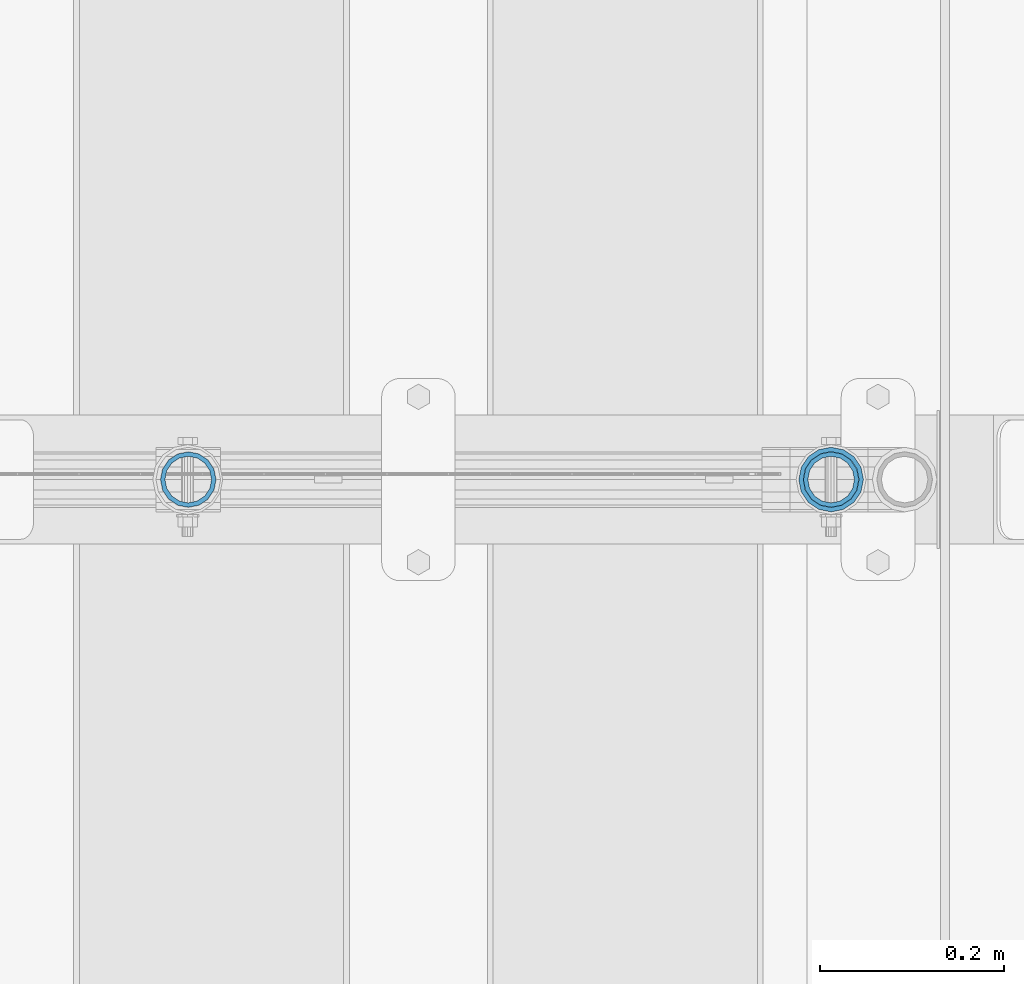
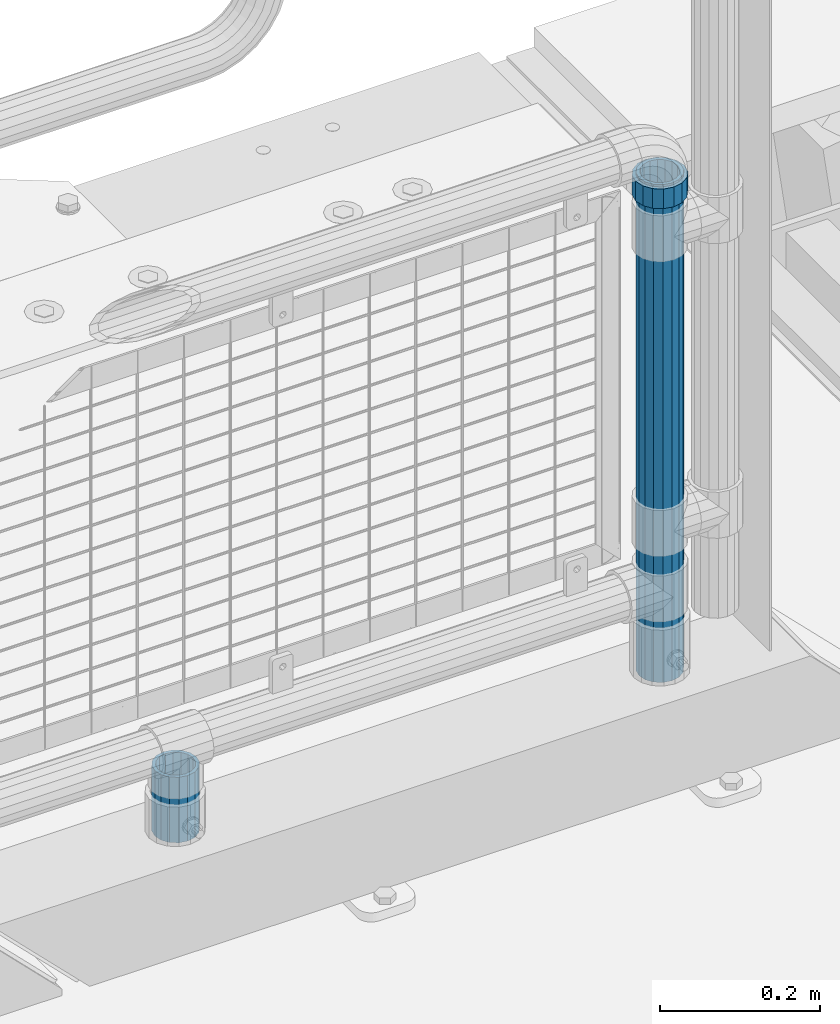
# One storey, part 111 of 270: 3 columns.
"""IFC2X3 building model written with IfcOpenShell, lengths in millimetres."""

from ifc_helpers import new_model, si_unit, frame, origin_with_axes, place, context, subcontext, project, spatial, faceted_brep, material, type_object, element, save


model = new_model("IFC2X3")

# Units and contexts
model_context = context("Model", 3, precision=1e-05, world=origin_with_axes())
body_context = subcontext(model_context, "Body", "Model", "MODEL_VIEW")
ifc_project = project(units=[si_unit("LENGTHUNIT", "METRE", prefix="MILLI"), si_unit("AREAUNIT", "SQUARE_METRE"), si_unit("VOLUMEUNIT", "CUBIC_METRE"), si_unit("MASSUNIT", "GRAM", prefix="KILO"), si_unit("TIMEUNIT", "SECOND"), si_unit("PLANEANGLEUNIT", "RADIAN"), si_unit("SOLIDANGLEUNIT", "STERADIAN"), si_unit("THERMODYNAMICTEMPERATUREUNIT", "DEGREE_CELSIUS"), si_unit("LUMINOUSINTENSITYUNIT", "LUMEN")], contexts=[model_context])

# Site, building, storey
site_placement = place(None, origin_with_axes())
site = spatial("IfcSite", under=ifc_project, at=site_placement, CompositionType="ELEMENT")
building_placement = place(site_placement, origin_with_axes())
building = spatial("IfcBuilding", under=site, at=building_placement, Name="Standard", CompositionType="ELEMENT")
storey_placement = place(building_placement, origin_with_axes())
storey = spatial("IfcBuildingStorey", under=building, at=storey_placement, Name="Undefined", CompositionType="ELEMENT", Elevation=0.0)

# Columns
ifc_material_1 = material()
column_type_1 = type_object("IfcColumnType", PredefinedType="NOTDEFINED")
column_1_placement = place(storey_placement, frame((19794.0, -16335.5, 168.02), z_axis=(-1.0, 0.0, 0.0), x_axis=(0.0, 0.0, 1.0)))
element("IfcColumn", 1, at=column_1_placement, inside=storey, type_object=column_type_1, material=ifc_material_1, context=body_context, shape_type="Brep", body=[
    faceted_brep([(0.0, -25.3500000000004, 0.0), (0.0, -23.4203461491616, 9.70102501045403), (760.0, -23.4203461491616, 9.70102501045403), (760.0, -25.3500000000004, 0.0), (0.0, -17.9251569030785, 17.9251569030785), (760.0, -17.9251569030785, 17.9251569030785), (0.0, -9.70102501045585, 23.4203461491597), (760.0, -9.70102501045585, 23.4203461491597), (0.0, 0.0, 25.3499999999985), (760.0, 0.0, 25.3499999999985), (0.0, 9.70102501045585, 23.4203461491597), (760.0, 9.70102501045585, 23.4203461491597), (0.0, 17.9251569030785, 17.9251569030785), (760.0, 17.9251569030785, 17.9251569030785), (0.0, 23.4203461491616, 9.70102501045403), (760.0, 23.4203461491616, 9.70102501045403), (0.0, 25.3500000000004, 0.0), (760.0, 25.3500000000004, 0.0), (0.0, 23.4203461491616, -9.70102501045403), (760.0, 23.4203461491616, -9.70102501045403), (0.0, 17.9251569030785, -17.9251569030785), (760.0, 17.9251569030785, -17.9251569030785), (0.0, 9.70102501045585, -23.4203461491597), (760.0, 9.70102501045585, -23.4203461491597), (0.0, 0.0, -25.3499999999985), (760.0, 0.0, -25.3499999999985), (0.0, -9.70102501045585, -23.4203461491597), (760.0, -9.70102501045585, -23.4203461491597), (0.0, -17.9251569030785, -17.9251569030785), (760.0, -17.9251569030785, -17.9251569030785), (0.0, -23.4203461491616, -9.70102501045403), (760.0, -23.4203461491616, -9.70102501045403), (0.0, -30.1499999999996, 0.0), (0.0, -27.8549679052157, -11.5379054858058), (760.0, -27.8549679052157, -11.5379054858058), (760.0, -30.1499999999996, 0.0), (0.0, -21.3192694527752, -21.3192694527752), (760.0, -21.3192694527752, -21.3192694527752), (0.0, -11.5379054858076, -27.8549679052157), (760.0, -11.5379054858076, -27.8549679052157), (0.0, 0.0, -30.1500000000015), (760.0, 0.0, -30.1500000000015), (0.0, 11.5379054858076, -27.8549679052157), (760.0, 11.5379054858076, -27.8549679052157), (0.0, 21.3192694527752, -21.3192694527752), (760.0, 21.3192694527752, -21.3192694527752), (0.0, 27.8549679052157, -11.5379054858058), (760.0, 27.8549679052157, -11.5379054858058), (0.0, 30.1499999999996, 0.0), (760.0, 30.1499999999996, 0.0), (0.0, 27.8549679052157, 11.5379054858058), (760.0, 27.8549679052157, 11.5379054858058), (0.0, 21.3192694527752, 21.3192694527752), (760.0, 21.3192694527752, 21.3192694527752), (0.0, 11.5379054858076, 27.8549679052157), (760.0, 11.5379054858076, 27.8549679052157), (0.0, 0.0, 30.1500000000015), (760.0, 0.0, 30.1500000000015), (0.0, -11.5379054858076, 27.8549679052157), (760.0, -11.5379054858076, 27.8549679052157), (0.0, -21.3192694527752, 21.3192694527752), (760.0, -21.3192694527752, 21.3192694527752), (0.0, -27.8549679052157, 11.5379054858058), (760.0, -27.8549679052157, 11.5379054858058)], [[[0, 1, 2, 3]], [[1, 4, 5, 2]], [[4, 6, 7, 5]], [[6, 8, 9, 7]], [[8, 10, 11, 9]], [[10, 12, 13, 11]], [[12, 14, 15, 13]], [[14, 16, 17, 15]], [[16, 18, 19, 17]], [[18, 20, 21, 19]], [[20, 22, 23, 21]], [[22, 24, 25, 23]], [[24, 26, 27, 25]], [[26, 28, 29, 27]], [[28, 30, 31, 29]], [[30, 0, 3, 31]], [[32, 33, 34, 35]], [[33, 36, 37, 34]], [[36, 38, 39, 37]], [[38, 40, 41, 39]], [[40, 42, 43, 41]], [[42, 44, 45, 43]], [[44, 46, 47, 45]], [[46, 48, 49, 47]], [[48, 50, 51, 49]], [[50, 52, 53, 51]], [[52, 54, 55, 53]], [[54, 56, 57, 55]], [[56, 58, 59, 57]], [[58, 60, 61, 59]], [[60, 62, 63, 61]], [[62, 32, 35, 63]], [[37, 39, 41, 43, 45, 47, 49, 51, 53, 55, 57, 59, 61, 63, 35, 34], [5, 7, 9, 11, 13, 15, 17, 19, 21, 23, 25, 27, 29, 31, 3, 2]], [[62, 60, 58, 56, 54, 52, 50, 48, 46, 44, 42, 40, 38, 36, 33, 32], [30, 28, 26, 24, 22, 20, 18, 16, 14, 12, 10, 8, 6, 4, 1, 0]]]),
])
column_2_placement = place(storey_placement, frame((19094.61, -16335.5, 168.02), z_axis=(-1.0, 0.0, 0.0), x_axis=(0.0, 0.0, 1.0)))
element("IfcColumn", 2, at=column_2_placement, inside=storey, type_object=column_type_1, material=ifc_material_1, context=body_context, shape_type="Brep", body=[
    faceted_brep([(0.0, -25.3500000000004, 0.0), (0.0, -23.4203461491616, 9.70102501045403), (100.0, -23.4203461491616, 9.70102501045403), (100.0, -25.3500000000004, 0.0), (0.0, -17.9251569030785, 17.9251569030785), (100.0, -17.9251569030785, 17.9251569030785), (0.0, -9.70102501045585, 23.4203461491597), (100.0, -9.70102501045585, 23.4203461491597), (0.0, 0.0, 25.3499999999985), (100.0, 0.0, 25.3499999999985), (0.0, 9.70102501045585, 23.4203461491597), (100.0, 9.70102501045585, 23.4203461491597), (0.0, 17.9251569030785, 17.9251569030785), (100.0, 17.9251569030785, 17.9251569030785), (0.0, 23.4203461491616, 9.70102501045403), (100.0, 23.4203461491616, 9.70102501045403), (0.0, 25.3500000000004, 0.0), (100.0, 25.3500000000004, 0.0), (0.0, 23.4203461491616, -9.70102501045403), (100.0, 23.4203461491616, -9.70102501045403), (0.0, 17.9251569030785, -17.9251569030785), (100.0, 17.9251569030785, -17.9251569030785), (0.0, 9.70102501045585, -23.4203461491597), (100.0, 9.70102501045585, -23.4203461491597), (0.0, 0.0, -25.3499999999985), (100.0, 0.0, -25.3499999999985), (0.0, -9.70102501045585, -23.4203461491597), (100.0, -9.70102501045585, -23.4203461491597), (0.0, -17.9251569030785, -17.9251569030785), (100.0, -17.9251569030785, -17.9251569030785), (0.0, -23.4203461491616, -9.70102501045403), (100.0, -23.4203461491616, -9.70102501045403), (0.0, -30.1499999999996, 0.0), (0.0, -27.8549679052157, -11.5379054858058), (100.0, -27.8549679052157, -11.5379054858058), (100.0, -30.1499999999996, 0.0), (0.0, -21.3192694527752, -21.3192694527752), (100.0, -21.3192694527752, -21.3192694527752), (0.0, -11.5379054858076, -27.8549679052157), (100.0, -11.5379054858076, -27.8549679052157), (0.0, 0.0, -30.1500000000015), (100.0, 0.0, -30.1500000000015), (0.0, 11.5379054858076, -27.8549679052157), (100.0, 11.5379054858076, -27.8549679052157), (0.0, 21.3192694527752, -21.3192694527752), (100.0, 21.3192694527752, -21.3192694527752), (0.0, 27.8549679052157, -11.5379054858058), (100.0, 27.8549679052157, -11.5379054858058), (0.0, 30.1499999999996, 0.0), (100.0, 30.1499999999996, 0.0), (0.0, 27.8549679052157, 11.5379054858058), (100.0, 27.8549679052157, 11.5379054858058), (0.0, 21.3192694527752, 21.3192694527752), (100.0, 21.3192694527752, 21.3192694527752), (0.0, 11.5379054858076, 27.8549679052157), (100.0, 11.5379054858076, 27.8549679052157), (0.0, 0.0, 30.1500000000015), (100.0, 0.0, 30.1500000000015), (0.0, -11.5379054858076, 27.8549679052157), (100.0, -11.5379054858076, 27.8549679052157), (0.0, -21.3192694527752, 21.3192694527752), (100.0, -21.3192694527752, 21.3192694527752), (0.0, -27.8549679052157, 11.5379054858058), (100.0, -27.8549679052157, 11.5379054858058)], [[[0, 1, 2, 3]], [[1, 4, 5, 2]], [[4, 6, 7, 5]], [[6, 8, 9, 7]], [[8, 10, 11, 9]], [[10, 12, 13, 11]], [[12, 14, 15, 13]], [[14, 16, 17, 15]], [[16, 18, 19, 17]], [[18, 20, 21, 19]], [[20, 22, 23, 21]], [[22, 24, 25, 23]], [[24, 26, 27, 25]], [[26, 28, 29, 27]], [[28, 30, 31, 29]], [[30, 0, 3, 31]], [[32, 33, 34, 35]], [[33, 36, 37, 34]], [[36, 38, 39, 37]], [[38, 40, 41, 39]], [[40, 42, 43, 41]], [[42, 44, 45, 43]], [[44, 46, 47, 45]], [[46, 48, 49, 47]], [[48, 50, 51, 49]], [[50, 52, 53, 51]], [[52, 54, 55, 53]], [[54, 56, 57, 55]], [[56, 58, 59, 57]], [[58, 60, 61, 59]], [[60, 62, 63, 61]], [[62, 32, 35, 63]], [[37, 39, 41, 43, 45, 47, 49, 51, 53, 55, 57, 59, 61, 63, 35, 34], [5, 7, 9, 11, 13, 15, 17, 19, 21, 23, 25, 27, 29, 31, 3, 2]], [[62, 60, 58, 56, 54, 52, 50, 48, 46, 44, 42, 40, 38, 36, 33, 32], [30, 28, 26, 24, 22, 20, 18, 16, 14, 12, 10, 8, 6, 4, 1, 0]]]),
])
ifc_material_2 = material(Name="Misc_Undefined")
column_type_2 = type_object("IfcColumnType", PredefinedType="NOTDEFINED")
column_3_placement = place(storey_placement, frame((19794.0, -16335.5, 894.85), z_axis=(1.0, 0.0, 0.0), x_axis=(0.0, 0.0, 1.0)))
element("IfcColumn", 3, at=column_3_placement, inside=storey, type_object=column_type_2, material=ifc_material_2, context=body_context, shape_type="Brep", body=[
    faceted_brep([(0.0, -30.3500000000004, 0.0), (0.0, -28.0397438117179, 11.614442172282), (30.0, -28.0397438117179, 11.6144421722805), (30.0, -30.3500000000004, 0.0), (0.0, -21.4606908090118, 21.46069080901), (30.0, -21.4606908090118, 21.4606908090117), (0.0, -11.6144421722802, 28.0397438117179), (30.0, -11.6144421722802, 28.0397438117176), (0.0, 0.0, 30.3499999999985), (30.0, 0.0, 30.35), (0.0, 11.6144421722802, 28.0397438117179), (30.0, 11.6144421722802, 28.0397438117176), (0.0, 21.4606908090118, 21.46069080901), (30.0, 21.4606908090118, 21.4606908090117), (0.0, 28.0397438117179, 11.614442172282), (30.0, 28.0397438117179, 11.6144421722805), (0.0, 30.3500000000004, 0.0), (30.0, 30.3500000000004, 0.0), (0.0, 28.0397438117179, -11.614442172282), (30.0, 28.0397438117179, -11.6144421722805), (0.0, 21.4606908090118, -21.46069080901), (30.0, 21.4606908090118, -21.4606908090117), (0.0, 11.6144421722802, -28.0397438117179), (30.0, 11.6144421722802, -28.0397438117176), (0.0, 0.0, -30.3499999999985), (30.0, 0.0, -30.35), (0.0, -11.6144421722802, -28.0397438117179), (30.0, -11.6144421722802, -28.0397438117176), (0.0, -21.4606908090118, -21.46069080901), (30.0, -21.4606908090118, -21.4606908090117), (0.0, -28.0397438117179, -11.614442172282), (30.0, -28.0397438117179, -11.6144421722805), (0.0, -35.1499999999996, 0.0), (0.0, -32.4743655677721, -13.4513226476338), (30.0, -32.4743655677721, -13.4513226476329), (30.0, -35.1499999999996, 0.0), (0.0, -24.8548033587067, -24.8548033587067), (30.0, -24.8548033587067, -24.8548033587072), (0.0, -13.4513226476338, -32.4743655677703), (30.0, -13.4513226476338, -32.4743655677718), (0.0, 0.0, -35.1499999999996), (30.0, 0.0, -35.15), (0.0, 13.4513226476338, -32.4743655677703), (30.0, 13.4513226476338, -32.4743655677718), (0.0, 24.8548033587067, -24.8548033587067), (30.0, 24.8548033587067, -24.8548033587072), (0.0, 32.4743655677721, -13.4513226476338), (30.0, 32.4743655677721, -13.4513226476329), (0.0, 35.1499999999996, 0.0), (30.0, 35.1499999999996, 0.0), (0.0, 32.4743655677721, 13.4513226476338), (30.0, 32.4743655677721, 13.4513226476329), (0.0, 24.8548033587067, 24.8548033587067), (30.0, 24.8548033587067, 24.8548033587072), (0.0, 13.4513226476338, 32.4743655677703), (30.0, 13.4513226476338, 32.4743655677718), (0.0, 0.0, 35.1499999999996), (30.0, 0.0, 35.15), (0.0, -13.4513226476338, 32.4743655677703), (30.0, -13.4513226476338, 32.4743655677718), (0.0, -24.8548033587067, 24.8548033587067), (30.0, -24.8548033587067, 24.8548033587072), (0.0, -32.4743655677721, 13.4513226476338), (30.0, -32.4743655677721, 13.4513226476329)], [[[0, 1, 2, 3]], [[1, 4, 5, 2]], [[4, 6, 7, 5]], [[6, 8, 9, 7]], [[8, 10, 11, 9]], [[10, 12, 13, 11]], [[12, 14, 15, 13]], [[14, 16, 17, 15]], [[16, 18, 19, 17]], [[18, 20, 21, 19]], [[20, 22, 23, 21]], [[22, 24, 25, 23]], [[24, 26, 27, 25]], [[26, 28, 29, 27]], [[28, 30, 31, 29]], [[30, 0, 3, 31]], [[32, 33, 34, 35]], [[33, 36, 37, 34]], [[36, 38, 39, 37]], [[38, 40, 41, 39]], [[40, 42, 43, 41]], [[42, 44, 45, 43]], [[44, 46, 47, 45]], [[46, 48, 49, 47]], [[48, 50, 51, 49]], [[50, 52, 53, 51]], [[52, 54, 55, 53]], [[54, 56, 57, 55]], [[56, 58, 59, 57]], [[58, 60, 61, 59]], [[60, 62, 63, 61]], [[62, 32, 35, 63]], [[37, 39, 41, 43, 45, 47, 49, 51, 53, 55, 57, 59, 61, 63, 35, 34], [5, 7, 9, 11, 13, 15, 17, 19, 21, 23, 25, 27, 29, 31, 3, 2]], [[62, 60, 58, 56, 54, 52, 50, 48, 46, 44, 42, 40, 38, 36, 33, 32], [30, 28, 26, 24, 22, 20, 18, 16, 14, 12, 10, 8, 6, 4, 1, 0]]]),
])

save(model, "model.ifc")
